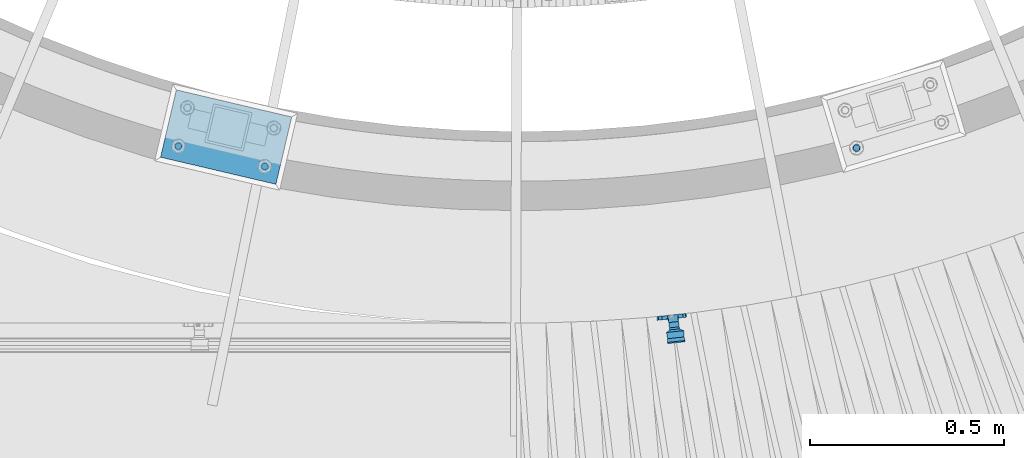
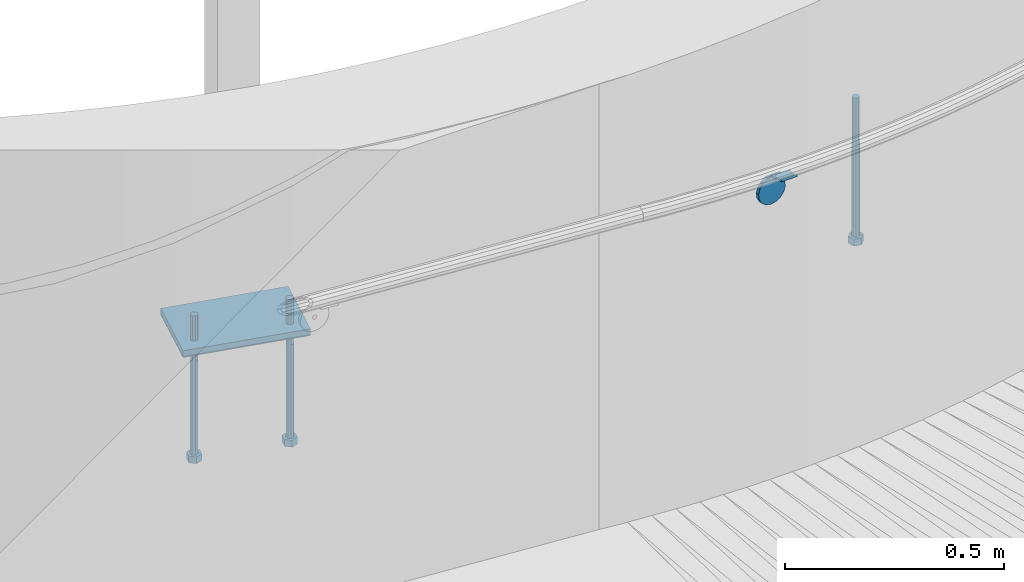
# One storey, part 460 of 975: 6 beams.
"""IFC2X3 building model written with IfcOpenShell, lengths in millimetres."""

from ifc_helpers import new_model, si_unit, frame, origin_with_axes, place, context, subcontext, project, spatial, faceted_brep, material, type_object, element, save


model = new_model("IFC2X3")

# Units and contexts
model_context = context("Model", 3, precision=1e-05, world=origin_with_axes())
body_context = subcontext(model_context, "Body", "Model", "MODEL_VIEW")
ifc_project = project(units=[si_unit("LENGTHUNIT", "METRE", prefix="MILLI"), si_unit("AREAUNIT", "SQUARE_METRE"), si_unit("VOLUMEUNIT", "CUBIC_METRE"), si_unit("MASSUNIT", "GRAM", prefix="KILO"), si_unit("TIMEUNIT", "SECOND"), si_unit("PLANEANGLEUNIT", "RADIAN"), si_unit("SOLIDANGLEUNIT", "STERADIAN"), si_unit("THERMODYNAMICTEMPERATUREUNIT", "DEGREE_CELSIUS"), si_unit("LUMINOUSINTENSITYUNIT", "LUMEN")], contexts=[model_context])

# Site, building, storey
site_placement = place(None, origin_with_axes())
site = spatial("IfcSite", under=ifc_project, at=site_placement, CompositionType="ELEMENT")
building_placement = place(site_placement, origin_with_axes())
building = spatial("IfcBuilding", under=site, at=building_placement, Name="Undefined", CompositionType="ELEMENT")
storey_placement = place(building_placement, origin_with_axes())
storey = spatial("IfcBuildingStorey", under=building, at=storey_placement, Name="Undefined", CompositionType="ELEMENT", Elevation=0.0)

# Beams
ifc_material_1 = material(Name="STEEL/A36")
beam_type_1 = type_object("IfcBeamType", PredefinedType="NOTDEFINED")
beam_1_placement = place(storey_placement, frame((35123.1119643137, -293.796156674146, 1668.71174649269), z_axis=(0.991559168911559, 0.105565719990649, -0.0752747853552238), x_axis=(-0.105864034992207, 0.994380613927093, 2.72239999874025e-05)))
element("IfcBeam", 1, at=beam_1_placement, inside=storey, type_object=beam_type_1, material=ifc_material_1, Name="WALL BRACKET", context=body_context, shape_type="Brep", body=[
    faceted_brep([(-1.09139364212751e-11, -35.1998101886752, 14.5802387730655), (0.0, -26.940768363208, 26.9407683632162), (1.2732925824821e-11, -14.5802387731151, 35.1998101887366), (0.0, 0.0, 38.0999984741211), (3.27418092638254e-11, 14.5802387730973, 35.1998101888166), (3.45607986673713e-11, 26.9407683631939, 26.9407683633472), (3.27418092638254e-11, 35.1998101886679, 14.5802387732328), (2.36468622460961e-11, 38.0999999999908, 8.73114913702011e-11), (1.45519152283669e-11, 35.1998101886752, -14.5802387730655), (1.81898940354586e-12, 26.9407683632071, -26.9407683632162), (-1.09139364212751e-11, 14.5802387731146, -35.1998101887511), (0.0, 0.0, -38.0999984741211), (-2.91038304567337e-11, -14.5802387730978, -35.1998101888239), (-3.27418092638254e-11, -26.9407683631948, -26.9407683633617), (-3.09228198602796e-11, -35.1998101886688, -14.5802387732401), (-2.36468622460961e-11, -38.0999999999917, -9.45874489843845e-11), (9.52499999999407, 35.4440469783465, 13.3523775149006), (9.52500000001783, 38.099999999989, 1.23691279441118e-10), (5.45819490078651, 35.1998101886775, 14.58023877304), (5.15915812204861, 35.4440469814256, 13.3523774994246), (5.15916016817869, 35.4440461871586, -13.3523814925829), (5.45819607316758, 35.1998101886757, -14.5802387731565), (9.52499999563867, 35.4440461839649, -13.352381508641), (9.52499999999338, 33.7468954266617, -16.754679378646), (9.52499999999418, 26.9407683632057, -26.9407683631944), (7.23710514487385, 33.7468954167059, -16.7546793935435), (9.52499999997963, 14.5802387731133, -35.199810188722), (9.52499999996871, 7.73070496506989e-12, -38.1000000000931), (9.52499999996326, -14.5802387730996, -35.1998101888021), (9.52499999995962, -26.9407683631966, -26.9407683633399), (9.5249999999578, -35.1998101886768, -14.5802387731064), (9.52499999997235, -38.0999999999935, -7.27595761418343e-11), (9.52499999988504, -35.1998101886779, 14.5802387731401), (9.52499999999418, -26.9407683632098, 26.940768363238), (9.52500000000691, -14.5802387731169, 35.1998101887584), (9.52500000001783, -1.13686837721616e-11, 38.1000000001295), (9.5250000000251, 14.580238773096, 35.1998101888312), (9.52500000002692, 26.9407683631925, 26.9407683633617), (7.23710629084189, 33.7468933804012, 16.7546824409801), (9.52500001802099, 33.74689339, 16.7546824266137), (4.12737783423069, 36.2867482851609, 11.6630037101459), (9.52500001480979, 36.2867482910076, 11.6630037099276), (1.9072828969438, 38.0999998001848, -4.3824766180478e-06), (9.43529109937867, 38.0999998083389, -4.38277129433118e-06), (4.12738199474541, 36.2867456530334, -11.6630120660157), (9.52499999713365, 36.2867456588801, -11.6630120662267), (9.52499998931302, 31.8782691818908, -20.5007361535354), (1.90728516843444, 38.0999984362613, -14.9620414784949), (9.43529504267332, 38.0999984471014, -14.9620414798228), (9.52499998867484, 31.8782692100656, -21.3428983101403), (-0.974480980704527, 40.4536660864392, -13.6176374922397), (6.55352889353486, 40.4536660972792, -13.617637493564), (-3.23293929398841, 48.4467136552532, -12.2071016444133), (-3.86099316375032, 48.9596734302611, -12.3332393299024), (-3.86099415506237, 48.9596734359397, 12.1506042690053), (-3.23294234398753, 48.4467162038179, 12.0244673261113), (6.55352388489973, 40.4536689343606, 13.4350048968336), (9.4352891744017, 38.1000015670843, 14.7794093900302), (-8.88876894391092, 51.462646060533, -12.9487245784876), (-14.5044020842531, 51.5524567377918, -12.9708091785214), (-14.5044031272276, 51.5524567437842, 12.788173508583), (-8.88876998507754, 51.4626460665079, 12.7660889411018), (-16.4483770195459, 51.1442726592504, -12.8704360163174), (-16.4483780543928, 51.1442726651987, 12.6878004343525), (-22.5793182144077, 51.3711360271759, -12.9262221073186), (-22.5793192537777, 51.3711360331463, 12.7435864607032), (-27.8885284154861, 54.4455780358899, -13.6822326528272), (-27.8885295160832, 54.4455780422152, 13.4995963000001), (-28.6196515649072, 55.6169452716154, -13.9702738582564), (-31.1370083013608, 59.6501226213948, -17.5950925222933), (-31.1370097188383, 59.6501226295447, 17.4124524185645), (-28.6196545294583, 55.616948227025, 13.7876379643458), (-33.6296792490059, 67.324805151891, -22.2250062266612), (-32.8101722890036, 64.8016260361878, -22.2250061928717), (-39.3161821982224, 64.9509398614337, -22.2250064563596), (-33.6296810489844, 67.3248051619378, 22.2249937734341), (-39.3127719838823, 64.95236112884, 22.2249935438595), (-32.8101756191698, 64.8016307577993, 22.2249938072164), (-49.8281982508399, 63.7590297560901, -21.2879733583577), (-49.8281999673757, 63.7590297658239, 21.1053316176076), (-62.537662592724, 64.8016282183019, -22.2250073966388), (-62.5376643923654, 64.8016282284259, 22.2249926034456), (-59.3629825026719, 68.3509998487543, 22.2249927311568), (-59.3629807030303, 68.3509998386305, -22.2250072689349), (-56.0005505059879, 61.6533412669896, 22.2249928688907), (-56.0009816237271, 61.6535489521873, 19.2130312653135), (-56.0009816302269, 64.8016307505561, 22.0423689734525), (-51.9930603186979, 64.8016307660225, 22.2249930304133), (-51.9930486616773, 64.8016260085653, -22.2250069696784), (-56.000981616694, 61.6535497473442, -22.2250071312228), (-56.0009816212363, 64.8016260027941, -22.2250068759422), (-56.0009816161877, 61.6535496925769, -19.3956728877092), (-50.6240356350016, 59.0640018412871, -17.0683164176735), (-50.6240370098228, 59.0640018490833, 16.8856764812081), (-37.4851004069614, 60.555058921409, -18.4084041452843), (-37.4851018904596, 60.555058929803, 18.2257636742615), (-36.5628425975134, 60.9400579463424, -18.7544220673662), (-36.5628441090176, 60.9400579547794, 18.5717814508498), (-35.6661101826384, 58.1791091500552, -16.2730189810172), (-35.6661114930633, 58.1791091575863, 16.0903794298065), (-34.0669073739811, 55.616948225869, 13.7876379531408), (-34.0669044052501, 55.6169452637716, -13.9702738572996), (-31.199578137138, 51.0230652214489, -12.8406309028251), (-31.1995791695818, 51.0230652273826, 12.6579953160217), (-13.5258453474495, 46.8920843628518, -12.4814476045976), (-10.0158535806146, 46.8359491542703, -12.491353805628), (-10.0158545847443, 46.8359491600327, 12.308720278641), (-13.5258463507973, 46.8920843686235, 12.298814059428), (-15.4698202757649, 46.4839002842855, -12.5534799881534), (-15.469821284944, 46.4839002900824, 12.3708465294185), (-23.8996230795056, 46.7958284847284, -12.4984339079674), (-23.8996240842331, 46.7958284904998, 12.3158003666576), (-26.7505131823156, 48.4467136213889, -12.207101640266), (-26.7505186046602, 48.4467161988273, 12.0244672777189), (-6.87329577845111, 45.2714927334573, -12.7674339683217), (-6.87329680492121, 45.2714927393397, 12.584800790275), (-0.974485553301008, 40.4536689327629, 13.4350048813394), (1.90728014135857, 38.100001565487, 14.7794093745397), (9.52500002100476, 31.8782677827221, 21.320715892205), (9.52500002038346, 31.878267810155, 20.5007393728483)], [[[0, 1, 2, 3, 4, 5, 6, 7, 8, 9, 10, 11, 12, 13, 14, 15]], [[16, 17, 7, 6, 18, 19]], [[20, 21, 8, 7, 17, 22]], [[23, 24, 9, 8, 21, 25]], [[10, 9, 24, 26]], [[11, 10, 26, 27]], [[12, 11, 27, 28]], [[13, 12, 28, 29]], [[14, 13, 29, 30]], [[15, 14, 30, 31]], [[0, 15, 31, 32]], [[1, 0, 32, 33]], [[2, 1, 33, 34]], [[3, 2, 34, 35]], [[4, 3, 35, 36]], [[5, 4, 36, 37]], [[38, 18, 6, 5, 37, 39]], [[39, 37, 36, 35, 34, 33, 32, 31, 30, 29, 28, 27, 26, 24, 23, 22, 17, 16]], [[40, 41, 16, 19]], [[40, 42, 43, 41]], [[42, 44, 45, 43]], [[46, 23, 25]], [[47, 48, 49]], [[48, 47, 50, 51]], [[51, 52, 53, 54, 55, 56, 57, 48]], [[58, 59, 60, 61]], [[59, 62, 63, 60]], [[62, 64, 65, 63]], [[64, 66, 67, 65]], [[66, 68, 69, 70, 71, 67]], [[72, 73, 74]], [[75, 76, 77]], [[74, 76, 75, 72]], [[74, 78, 79, 76]], [[80, 81, 82, 83]], [[84, 85, 86]], [[82, 81, 84, 86, 87]], [[78, 88, 83, 82, 87, 79]], [[89, 80, 83, 88, 90]], [[89, 90, 91]], [[84, 81, 80, 89, 91, 92, 93, 85]], [[92, 94, 95, 93]], [[94, 96, 97, 95]], [[96, 98, 99, 97]], [[70, 77, 76, 79, 87, 86, 85, 93, 95, 97, 99, 100, 71]], [[69, 73, 72, 75, 77, 70]], [[68, 101, 98, 96, 94, 92, 91, 90, 88, 78, 74, 73, 69]], [[99, 98, 101, 102, 103, 100]], [[104, 105, 106, 107]], [[108, 104, 107, 109]], [[110, 108, 109, 111]], [[103, 102, 112, 110, 111, 113]], [[54, 61, 60, 63, 65, 67, 71, 100, 103, 113, 55]], [[53, 58, 61, 54]], [[52, 112, 102, 101, 68, 66, 64, 62, 59, 58, 53]], [[51, 50, 114, 105, 104, 108, 110, 112, 52]], [[105, 114, 115, 106]], [[55, 113, 111, 109, 107, 106, 115, 116, 56]], [[56, 116, 117, 57]], [[117, 118, 57]], [[39, 16, 41, 43, 45, 22, 23, 46, 49, 48, 57, 118, 119]], [[119, 38, 39]], [[119, 118, 117, 116, 115, 114, 50, 47, 49, 46, 25, 21, 20, 44, 42, 40, 19, 18, 38]], [[45, 44, 20, 22]]]),
])
ifc_material_2 = material(Name="STEEL/F1554-36")
beam_type_2 = type_object("IfcBeamType", PredefinedType="NOTDEFINED")
beam_2_placement = place(storey_placement, frame((33853.4254815491, 150.222817382735, 1371.6), z_axis=(0.973539033329667, -0.228520788077446, 0.0), x_axis=(0.0, 0.0, -1.0)))
element("IfcBeam", 2, at=beam_2_placement, inside=storey, type_object=beam_type_2, material=ifc_material_2, Name="HEADED_ANCHOR_BOLT", context=body_context, shape_type="Brep", body=[
    faceted_brep([(260.34375, -9.13000011445183, 15.8100004195221), (260.34375, -18.2600002289691, -1.45519152283669e-11), (279.393749999999, -18.2600002289691, -1.45519152283669e-11), (279.393749999999, -9.13000011445183, 15.8100004195221), (260.34375, 9.13000011451732, 15.8100004195403), (279.393749999999, 9.13000011451732, 15.8100004195403), (260.34375, 18.2600002289728, 1.81898940354586e-11), (279.393749999999, 18.2600002289728, 1.81898940354586e-11), (260.34375, 9.13000011445547, -15.8100004195221), (279.393749999999, 9.13000011445547, -15.8100004195221), (260.34375, -9.13000011451732, -15.8100004195367), (279.393749999999, -9.13000011451732, -15.8100004195367), (260.34375, -4.47768005528269, 9.29799844174704), (260.34375, -8.06850066050174, 6.43441456486471), (260.34375, -10.0612557562381, 2.29641597050068), (260.34375, -10.0612557562454, -2.29641597051523), (260.34375, -8.06850066052721, -6.43441456487926), (260.34375, -4.47768005531907, -9.29799844175068), (260.34375, -1.81898940354586e-11, -10.319999694766), (260.34375, 4.47768005528633, -9.2979984417434), (260.34375, 8.06850066050174, -6.43441456486471), (260.34375, 10.0612557562381, -2.29641597050068), (260.34375, 10.0612557562454, 2.29641597051886), (260.34375, 8.06850066052357, 6.4344145648829), (260.34375, 4.47768005532271, 9.29799844175432), (260.34375, 2.18278728425503e-11, 10.3199996947696), (279.393749999999, 2.18278728425503e-11, 10.3199996947696), (279.393749999999, -4.47768005528269, 9.29799844174704), (279.393749999999, -8.06850066050174, 6.43441456486471), (279.393749999999, -10.0612557562381, 2.29641597050068), (279.393749999999, -10.0612557562454, -2.29641597051523), (279.393749999999, -8.06850066052721, -6.43441456487926), (279.393749999999, -4.47768005531907, -9.29799844175068), (279.393749999999, -1.81898940354586e-11, -10.319999694766), (279.393749999999, 4.47768005528633, -9.2979984417434), (279.393749999999, 8.06850066050174, -6.43441456486471), (279.393749999999, 10.0612557562381, -2.29641597050068), (279.393749999999, 10.0612557562454, 2.29641597051886), (279.393749999999, 8.06850066052357, 6.4344145648829), (279.393749999999, 4.47768005532271, 9.29799844175432), (0.0, -6.73519209080223, 6.73519209080186), (0.0, -9.52499999999964, 0.0), (279.400000000001, -9.52499999999782, -3.63797880709171e-12), (279.400000000001, -6.73519209079313, 6.73519209079313), (-9.87109982941227e-13, -1.20792265079217e-13, 9.52499961853027), (279.400000000001, 1.09139364212751e-11, 9.52499999999054), (0.0, 6.73519209080223, 6.73519209080186), (279.400000000001, 6.73519209081132, 6.73519209079677), (0.0, 9.52499999999964, 0.0), (279.400000000001, 9.52500000000146, 3.63797880709171e-12), (0.0, 6.73519209080223, -6.73519209080186), (279.400000000001, 6.73519209079677, -6.73519209079313), (2.95075507493764e-12, -1.20792265079217e-13, -9.52499961853027), (279.400000000001, -1.09139364212751e-11, -9.5249999999869), (-126.99791499542, -6.36396103070001, 6.3639610306418), (-126.99791499542, 1.81898940354586e-11, 8.99999999995271), (-126.99791499542, 6.36396103072184, 6.36396103065272), (-126.99791499542, 9.00000000004366, 1.09139364212751e-11), (-126.99791499542, 6.36396103069637, -6.3639610306418), (-126.99791499542, -1.81898940354586e-11, -8.99999999995271), (-126.99791499542, -6.36396103072184, -6.36396103064908), (-126.99791499542, -9.00000000004002, -7.27595761418343e-12), (0.0149743263646087, 6.36396103067818, -6.36396103067909), (0.0149743263646087, 0.0, -9.0), (0.0149743263646087, -6.36396103067818, -6.36396103067909), (0.0149743263987148, -8.9999995411581, -1.00796984270346e-06), (0.0149743263646087, -6.36396103067818, 6.36396103067909), (0.0149743263646087, 0.0, 9.0), (0.0149743263646087, 6.36396103067818, 6.36396103067909), (0.0149743263987148, 9.0000004588419, -1.00796984270346e-06), (0.0, -6.73519209080223, -6.73519209080186), (279.400000000001, -6.73519209080769, -6.73519209079677)], [[[0, 1, 2, 3]], [[4, 0, 3, 5]], [[6, 4, 5, 7]], [[8, 6, 7, 9]], [[10, 8, 9, 11]], [[0, 4, 6, 8, 10, 1], [12, 13, 14, 15, 16, 17, 18, 19, 20, 21, 22, 23, 24, 25]], [[12, 25, 26, 27]], [[13, 12, 27, 28]], [[14, 13, 28, 29]], [[15, 14, 29, 30]], [[16, 15, 30, 31]], [[17, 16, 31, 32]], [[18, 17, 32, 33]], [[19, 18, 33, 34]], [[20, 19, 34, 35]], [[21, 20, 35, 36]], [[22, 21, 36, 37]], [[23, 22, 37, 38]], [[24, 23, 38, 39]], [[25, 24, 39, 26]], [[9, 7, 5, 3, 2, 11], [38, 37, 36, 35, 34, 33, 32, 31, 30, 29, 28, 27, 26, 39]], [[1, 10, 11, 2]], [[40, 41, 42, 43]], [[44, 40, 43, 45]], [[46, 44, 45, 47]], [[48, 46, 47, 49]], [[50, 48, 49, 51]], [[52, 50, 51, 53]], [[54, 55, 56, 57, 58, 59, 60, 61]], [[59, 58, 62, 63]], [[60, 59, 63, 64]], [[61, 60, 64, 65]], [[54, 61, 65, 66]], [[55, 54, 66, 67]], [[56, 55, 67, 68]], [[57, 56, 68, 69]], [[58, 57, 69, 62]], [[40, 44, 46, 48, 50, 52, 70, 41], [68, 67, 66, 65, 64, 63, 62, 69]], [[41, 70, 71, 42]], [[53, 51, 49, 47, 45, 43, 42, 71]], [[70, 52, 53, 71]]]),
])
beam_3_placement = place(storey_placement, frame((34075.976504568, 97.9829652280884, 1371.6), z_axis=(0.973539033329667, -0.228520788077446, 0.0), x_axis=(0.0, 0.0, -1.0)))
element("IfcBeam", 3, at=beam_3_placement, inside=storey, type_object=beam_type_2, material=ifc_material_2, Name="HEADED_ANCHOR_BOLT", context=body_context, shape_type="Brep", body=[
    faceted_brep([(260.34375, -9.13000011445183, 15.8100004195221), (260.34375, -18.2600002289691, -1.45519152283669e-11), (279.393749999999, -18.2600002289691, -1.45519152283669e-11), (279.393749999999, -9.13000011445183, 15.8100004195221), (260.34375, 9.13000011451732, 15.8100004195403), (279.393749999999, 9.13000011451732, 15.8100004195403), (260.34375, 18.2600002289728, 1.81898940354586e-11), (279.393749999999, 18.2600002289728, 1.81898940354586e-11), (260.34375, 9.13000011445547, -15.8100004195221), (279.393749999999, 9.13000011445547, -15.8100004195221), (260.34375, -9.13000011451732, -15.8100004195367), (279.393749999999, -9.13000011451732, -15.8100004195367), (260.34375, -4.47768005528269, 9.29799844174704), (260.34375, -8.06850066050174, 6.43441456486471), (260.34375, -10.0612557562381, 2.29641597050068), (260.34375, -10.0612557562454, -2.29641597051523), (260.34375, -8.06850066052721, -6.43441456487926), (260.34375, -4.47768005531907, -9.29799844175068), (260.34375, -1.81898940354586e-11, -10.319999694766), (260.34375, 4.47768005528633, -9.2979984417434), (260.34375, 8.06850066050174, -6.43441456486471), (260.34375, 10.0612557562381, -2.29641597050068), (260.34375, 10.0612557562454, 2.29641597051886), (260.34375, 8.06850066052357, 6.4344145648829), (260.34375, 4.47768005532271, 9.29799844175432), (260.34375, 2.18278728425503e-11, 10.3199996947696), (279.393749999999, 2.18278728425503e-11, 10.3199996947696), (279.393749999999, -4.47768005528269, 9.29799844174704), (279.393749999999, -8.06850066050174, 6.43441456486471), (279.393749999999, -10.0612557562381, 2.29641597050068), (279.393749999999, -10.0612557562454, -2.29641597051523), (279.393749999999, -8.06850066052721, -6.43441456487926), (279.393749999999, -4.47768005531907, -9.29799844175068), (279.393749999999, -1.81898940354586e-11, -10.319999694766), (279.393749999999, 4.47768005528633, -9.2979984417434), (279.393749999999, 8.06850066050174, -6.43441456486471), (279.393749999999, 10.0612557562381, -2.29641597050068), (279.393749999999, 10.0612557562454, 2.29641597051886), (279.393749999999, 8.06850066052357, 6.4344145648829), (279.393749999999, 4.47768005532271, 9.29799844175432), (0.0, -6.73519209080223, 6.73519209080186), (0.0, -9.52499999999964, 0.0), (279.400000000001, -9.52499999999782, -3.63797880709171e-12), (279.400000000001, -6.73519209079313, 6.73519209079313), (-9.87109982941227e-13, -1.20792265079217e-13, 9.52499961853027), (279.400000000001, 1.09139364212751e-11, 9.52499999999054), (0.0, 6.73519209080223, 6.73519209080186), (279.400000000001, 6.73519209081132, 6.73519209079677), (0.0, 9.52499999999964, 0.0), (279.400000000001, 9.52500000000146, 3.63797880709171e-12), (0.0, 6.73519209080223, -6.73519209080186), (279.400000000001, 6.73519209079677, -6.73519209079313), (2.95075507493764e-12, -1.20792265079217e-13, -9.52499961853027), (279.400000000001, -1.09139364212751e-11, -9.5249999999869), (-126.99791499542, -6.36396103070001, 6.3639610306418), (-126.99791499542, 1.81898940354586e-11, 8.99999999995271), (-126.99791499542, 6.36396103072184, 6.36396103065272), (-126.99791499542, 9.00000000004366, 1.09139364212751e-11), (-126.99791499542, 6.36396103069637, -6.3639610306418), (-126.99791499542, -1.81898940354586e-11, -8.99999999995271), (-126.99791499542, -6.36396103072184, -6.36396103064908), (-126.99791499542, -9.00000000004002, -7.27595761418343e-12), (0.0149743263646087, 6.36396103067818, -6.36396103067909), (0.0149743263646087, 0.0, -9.0), (0.0149743263646087, -6.36396103067818, -6.36396103067909), (0.0149743263987148, -8.9999995411581, -1.00796984270346e-06), (0.0149743263646087, -6.36396103067818, 6.36396103067909), (0.0149743263646087, 0.0, 9.0), (0.0149743263646087, 6.36396103067818, 6.36396103067909), (0.0149743263987148, 9.0000004588419, -1.00796984270346e-06), (0.0, -6.73519209080223, -6.73519209080186), (279.400000000001, -6.73519209080769, -6.73519209079677)], [[[0, 1, 2, 3]], [[4, 0, 3, 5]], [[6, 4, 5, 7]], [[8, 6, 7, 9]], [[10, 8, 9, 11]], [[0, 4, 6, 8, 10, 1], [12, 13, 14, 15, 16, 17, 18, 19, 20, 21, 22, 23, 24, 25]], [[12, 25, 26, 27]], [[13, 12, 27, 28]], [[14, 13, 28, 29]], [[15, 14, 29, 30]], [[16, 15, 30, 31]], [[17, 16, 31, 32]], [[18, 17, 32, 33]], [[19, 18, 33, 34]], [[20, 19, 34, 35]], [[21, 20, 35, 36]], [[22, 21, 36, 37]], [[23, 22, 37, 38]], [[24, 23, 38, 39]], [[25, 24, 39, 26]], [[9, 7, 5, 3, 2, 11], [38, 37, 36, 35, 34, 33, 32, 31, 30, 29, 28, 27, 26, 39]], [[1, 10, 11, 2]], [[40, 41, 42, 43]], [[44, 40, 43, 45]], [[46, 44, 45, 47]], [[48, 46, 47, 49]], [[50, 48, 49, 51]], [[52, 50, 51, 53]], [[54, 55, 56, 57, 58, 59, 60, 61]], [[59, 58, 62, 63]], [[60, 59, 63, 64]], [[61, 60, 64, 65]], [[54, 61, 65, 66]], [[55, 54, 66, 67]], [[56, 55, 67, 68]], [[57, 56, 68, 69]], [[58, 57, 69, 62]], [[40, 44, 46, 48, 50, 52, 70, 41], [68, 67, 66, 65, 64, 63, 62, 69]], [[41, 70, 71, 42]], [[53, 51, 49, 47, 45, 43, 42, 71]], [[70, 52, 53, 71]]]),
])
beam_4_placement = place(storey_placement, frame((35598.1600575667, 145.540930828603, 1371.6), z_axis=(0.957369928409554, 0.288864709123642, 0.0), x_axis=(0.0, 0.0, -1.0)))
element("IfcBeam", 4, at=beam_4_placement, inside=storey, type_object=beam_type_2, material=ifc_material_2, Name="HEADED_ANCHOR_BOLT", context=body_context, shape_type="Brep", body=[
    faceted_brep([(260.34375, -9.13000011445183, 15.8100004195221), (260.34375, -18.2600002289691, -1.45519152283669e-11), (279.393749999999, -18.2600002289691, -1.45519152283669e-11), (279.393749999999, -9.13000011445183, 15.8100004195221), (260.34375, 9.13000011451732, 15.8100004195403), (279.393749999999, 9.13000011451732, 15.8100004195403), (260.34375, 18.2600002289728, 1.81898940354586e-11), (279.393749999999, 18.2600002289728, 1.81898940354586e-11), (260.34375, 9.13000011445547, -15.8100004195221), (279.393749999999, 9.13000011445547, -15.8100004195221), (260.34375, -9.13000011451732, -15.8100004195367), (279.393749999999, -9.13000011451732, -15.8100004195367), (260.34375, -4.47768005528269, 9.29799844174704), (260.34375, -8.06850066050174, 6.43441456486471), (260.34375, -10.0612557562381, 2.29641597050068), (260.34375, -10.0612557562454, -2.29641597051523), (260.34375, -8.06850066052721, -6.43441456487926), (260.34375, -4.47768005531907, -9.29799844175068), (260.34375, -1.81898940354586e-11, -10.319999694766), (260.34375, 4.47768005528633, -9.2979984417434), (260.34375, 8.06850066050174, -6.43441456486471), (260.34375, 10.0612557562381, -2.29641597050068), (260.34375, 10.0612557562454, 2.29641597051886), (260.34375, 8.06850066052357, 6.4344145648829), (260.34375, 4.47768005532271, 9.29799844175432), (260.34375, 2.18278728425503e-11, 10.3199996947696), (279.393749999999, 2.18278728425503e-11, 10.3199996947696), (279.393749999999, -4.47768005528269, 9.29799844174704), (279.393749999999, -8.06850066050174, 6.43441456486471), (279.393749999999, -10.0612557562381, 2.29641597050068), (279.393749999999, -10.0612557562454, -2.29641597051523), (279.393749999999, -8.06850066052721, -6.43441456487926), (279.393749999999, -4.47768005531907, -9.29799844175068), (279.393749999999, -1.81898940354586e-11, -10.319999694766), (279.393749999999, 4.47768005528633, -9.2979984417434), (279.393749999999, 8.06850066050174, -6.43441456486471), (279.393749999999, 10.0612557562381, -2.29641597050068), (279.393749999999, 10.0612557562454, 2.29641597051886), (279.393749999999, 8.06850066052357, 6.4344145648829), (279.393749999999, 4.47768005532271, 9.29799844175432), (0.0, -6.73519209080223, 6.73519209080186), (0.0, -9.52499999999964, 0.0), (279.400000000001, -9.52499999999782, -3.63797880709171e-12), (279.400000000001, -6.73519209079313, 6.73519209079313), (-9.87109982941227e-13, -1.20792265079217e-13, 9.52499961853027), (279.400000000001, 1.09139364212751e-11, 9.52499999999054), (0.0, 6.73519209080223, 6.73519209080186), (279.400000000001, 6.73519209081132, 6.73519209079677), (0.0, 9.52499999999964, 0.0), (279.400000000001, 9.52500000000146, 3.63797880709171e-12), (0.0, 6.73519209080223, -6.73519209080186), (279.400000000001, 6.73519209079677, -6.73519209079313), (2.95075507493764e-12, -1.20792265079217e-13, -9.52499961853027), (279.400000000001, -1.09139364212751e-11, -9.5249999999869), (-126.99791499542, -6.36396103070001, 6.3639610306418), (-126.99791499542, 1.81898940354586e-11, 8.99999999995271), (-126.99791499542, 6.36396103072184, 6.36396103065272), (-126.99791499542, 9.00000000004366, 1.09139364212751e-11), (-126.99791499542, 6.36396103069637, -6.3639610306418), (-126.99791499542, -1.81898940354586e-11, -8.99999999995271), (-126.99791499542, -6.36396103072184, -6.36396103064908), (-126.99791499542, -9.00000000004002, -7.27595761418343e-12), (0.0149743263646087, 6.36396103067818, -6.36396103067909), (0.0149743263646087, 0.0, -9.0), (0.0149743263646087, -6.36396103067818, -6.36396103067909), (0.0149743263987148, -8.9999995411581, -1.00796984270346e-06), (0.0149743263646087, -6.36396103067818, 6.36396103067909), (0.0149743263646087, 0.0, 9.0), (0.0149743263646087, 6.36396103067818, 6.36396103067909), (0.0149743263987148, 9.0000004588419, -1.00796984270346e-06), (0.0, -6.73519209080223, -6.73519209080186), (279.400000000001, -6.73519209080769, -6.73519209079677)], [[[0, 1, 2, 3]], [[4, 0, 3, 5]], [[6, 4, 5, 7]], [[8, 6, 7, 9]], [[10, 8, 9, 11]], [[0, 4, 6, 8, 10, 1], [12, 13, 14, 15, 16, 17, 18, 19, 20, 21, 22, 23, 24, 25]], [[12, 25, 26, 27]], [[13, 12, 27, 28]], [[14, 13, 28, 29]], [[15, 14, 29, 30]], [[16, 15, 30, 31]], [[17, 16, 31, 32]], [[18, 17, 32, 33]], [[19, 18, 33, 34]], [[20, 19, 34, 35]], [[21, 20, 35, 36]], [[22, 21, 36, 37]], [[23, 22, 37, 38]], [[24, 23, 38, 39]], [[25, 24, 39, 26]], [[9, 7, 5, 3, 2, 11], [38, 37, 36, 35, 34, 33, 32, 31, 30, 29, 28, 27, 26, 39]], [[1, 10, 11, 2]], [[40, 41, 42, 43]], [[44, 40, 43, 45]], [[46, 44, 45, 47]], [[48, 46, 47, 49]], [[50, 48, 49, 51]], [[52, 50, 51, 53]], [[54, 55, 56, 57, 58, 59, 60, 61]], [[59, 58, 62, 63]], [[60, 59, 63, 64]], [[61, 60, 64, 65]], [[54, 61, 65, 66]], [[55, 54, 66, 67]], [[56, 55, 67, 68]], [[57, 56, 68, 69]], [[58, 57, 69, 62]], [[40, 44, 46, 48, 50, 52, 70, 41], [68, 67, 66, 65, 64, 63, 62, 69]], [[41, 70, 71, 42]], [[53, 51, 49, 47, 45, 43, 42, 71]], [[70, 52, 53, 71]]]),
])
beam_type_3 = type_object("IfcBeamType", PredefinedType="NOTDEFINED")
beam_5_placement = place(storey_placement, frame((34124.6771977718, 138.732106095676, 1419.225), z_axis=(-0.228520788077446, -0.973539033329667, 0.0), x_axis=(-0.973539033329667, 0.228520788077446, 0.0)))
element("IfcBeam", 5, at=beam_5_placement, inside=storey, type_object=beam_type_3, material=ifc_material_1, Name="PLATE", context=body_context, shape_type="Brep", body=[
    faceted_brep([(0.0, 9.52499999999964, -88.9000000000015), (0.0, 9.52499999999964, 88.9000000000015), (304.800000000429, 9.52500000000009, 88.9000000003653), (304.800000000414, 9.52500000000009, -88.8999999996704), (0.0, -9.52499999999964, 88.9000000000015), (304.800000000429, -9.52500000000009, 88.9000000003653), (0.0, -9.52499999999964, -88.9000000000015), (304.800000000414, -9.52500000000009, -88.8999999996704)], [[[0, 1, 2, 3]], [[1, 4, 5, 2]], [[4, 6, 7, 5]], [[6, 0, 3, 7]], [[5, 7, 3, 2]], [[6, 4, 1, 0]]]),
])
beam_type_4 = type_object("IfcBeamType", PredefinedType="NOTDEFINED")
beam_6_placement = place(storey_placement, frame((34124.6771977719, 138.732106095754, 1411.2875), z_axis=(-0.228520788077446, -0.973539033329667, 0.0), x_axis=(-0.973539033329667, 0.228520788077446, 0.0)))
element("IfcBeam", 6, at=beam_6_placement, inside=storey, type_object=beam_type_4, material=ifc_material_1, Name="TEMPLATE", context=body_context, shape_type="Brep", body=[
    faceted_brep([(-1.09139364212751e-11, 1.58750000000009, -88.900000000016), (3.63797880709171e-12, 1.58750000000009, 88.9000000000196), (304.800000000418, 1.58750000000009, 88.9000000003762), (304.800000000399, 1.58750000000009, -88.8999999996631), (3.63797880709171e-12, -1.58750000000009, 88.9000000000196), (304.800000000418, -1.58750000000009, 88.9000000003762), (-1.09139364212751e-11, -1.58750000000009, -88.900000000016), (304.800000000399, -1.58750000000009, -88.8999999996631)], [[[0, 1, 2, 3]], [[1, 4, 5, 2]], [[4, 6, 7, 5]], [[6, 0, 3, 7]], [[5, 7, 3, 2]], [[6, 4, 1, 0]]]),
])

save(model, "model.ifc")
